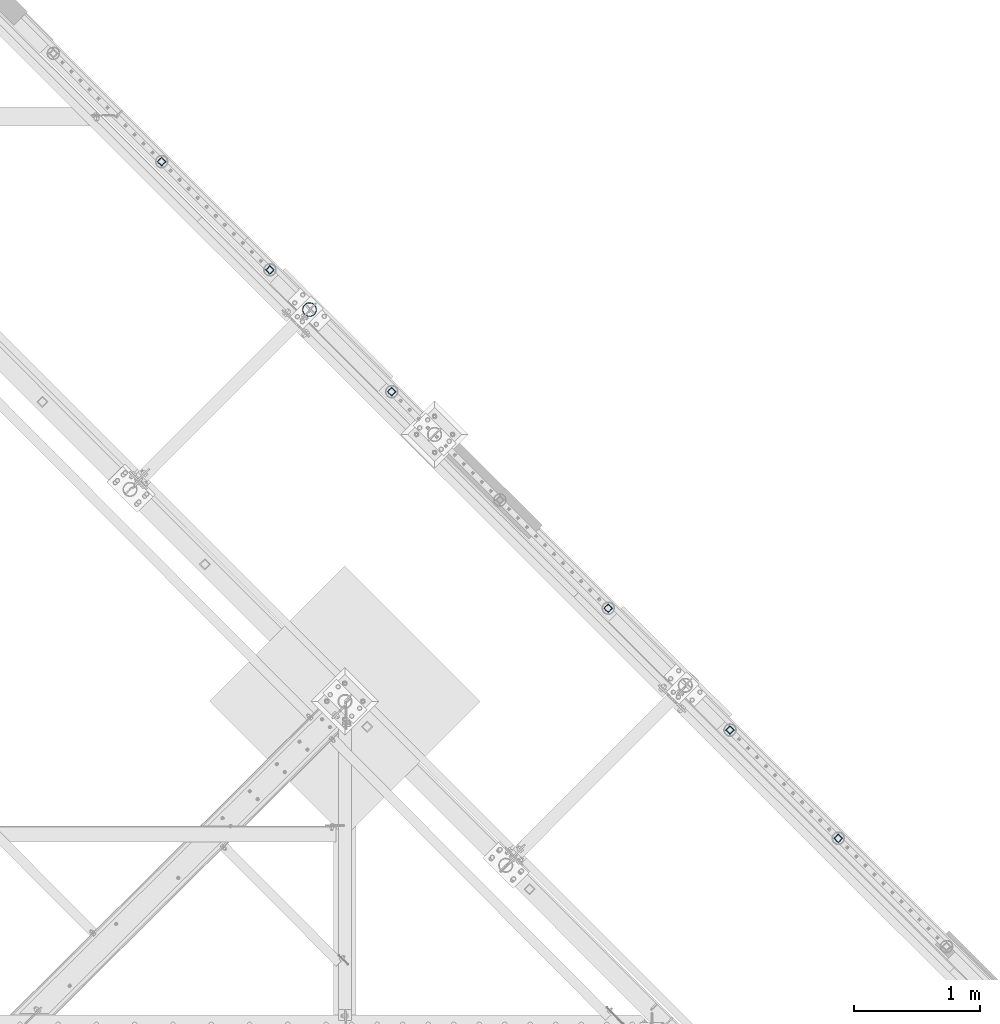
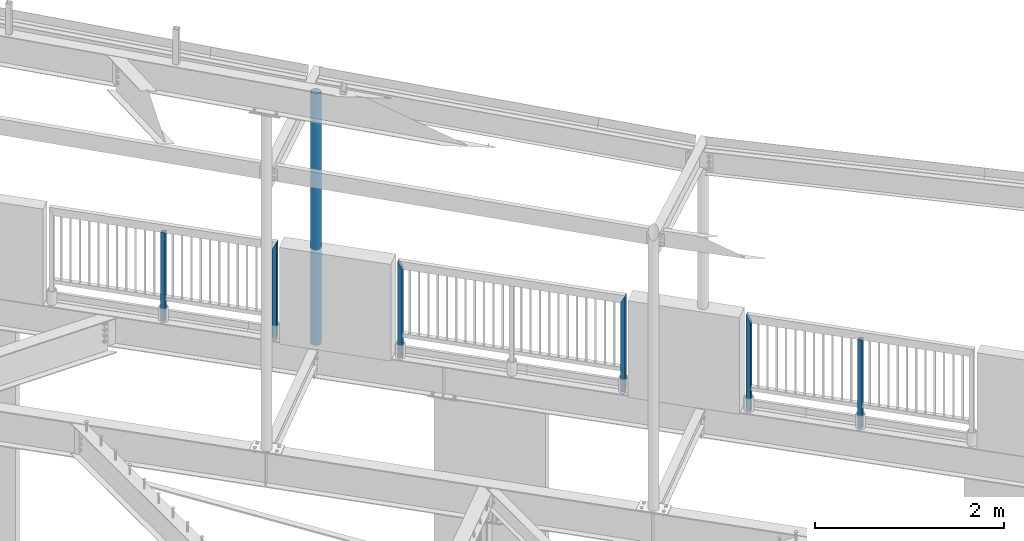
# One storey, part 139 of 975: 7 columns.
"""IFC2X3 building model written with IfcOpenShell, lengths in millimetres."""

from ifc_helpers import new_model, si_unit, frame, origin_with_axes, place, context, subcontext, project, spatial, faceted_brep, material, type_object, element, save


model = new_model("IFC2X3")

# Units and contexts
model_context = context("Model", 3, precision=1e-05, world=origin_with_axes())
body_context = subcontext(model_context, "Body", "Model", "MODEL_VIEW")
ifc_project = project(units=[si_unit("LENGTHUNIT", "METRE", prefix="MILLI"), si_unit("AREAUNIT", "SQUARE_METRE"), si_unit("VOLUMEUNIT", "CUBIC_METRE"), si_unit("MASSUNIT", "GRAM", prefix="KILO"), si_unit("TIMEUNIT", "SECOND"), si_unit("PLANEANGLEUNIT", "RADIAN"), si_unit("SOLIDANGLEUNIT", "STERADIAN"), si_unit("THERMODYNAMICTEMPERATUREUNIT", "DEGREE_CELSIUS"), si_unit("LUMINOUSINTENSITYUNIT", "LUMEN")], contexts=[model_context])

# Site, building, storey
site_placement = place(None, origin_with_axes())
site = spatial("IfcSite", under=ifc_project, at=site_placement, CompositionType="ELEMENT")
building_placement = place(site_placement, origin_with_axes())
building = spatial("IfcBuilding", under=site, at=building_placement, Name="Undefined", CompositionType="ELEMENT")
storey_placement = place(building_placement, origin_with_axes())
storey = spatial("IfcBuildingStorey", under=building, at=storey_placement, Name="Undefined", CompositionType="ELEMENT", Elevation=0.0)

# Columns
ifc_material_1 = material()
column_type_1 = type_object("IfcColumnType", Name="HSS2X2X.188_TUBES", PredefinedType="NOTDEFINED")
column_1_placement = place(storey_placement, frame((28372.9579755447, 20262.0679609286, 3937.00071954323), z_axis=(-0.707106781186601, 0.707106781186494, 2.36468622460961e-14), x_axis=(-5.04999999806568e-07, 5.04999999806568e-07, 0.999999999999745)))
element("IfcColumn", 1, at=column_1_placement, inside=storey, type_object=column_type_1, material=ifc_material_1, Name="HANDRAIL", ObjectType="HSS2X2X.188_TUBES", context=body_context, shape_type="Brep", body=[
    faceted_brep([(0.0, 20.6374999999753, -20.6375000000298), (0.0, -20.6375000000153, -20.6375000000153), (1142.9992657244, -20.6374999999534, -20.6375000019689), (1142.99926572435, 20.6374999999462, -20.6375000019689), (0.0, -20.6374999999825, 20.6375000000335), (1142.99929520217, -20.6374999999607, 20.6374999979416), (0.0, 20.6375000000116, 20.6375000000189), (1142.99929520212, 20.6374999999462, 20.6374999979416), (0.0, 25.3999999999724, -25.4000000000342), (0.0, 25.400000000016, 25.4000000000196), (1142.99929860339, 25.399999999936, 25.3999999979333), (1142.99926232306, 25.399999999936, -25.4000000019587), (0.0, -25.399999999976, 25.4000000000378), (1142.99929860346, -25.3999999999432, 25.3999999979333), (0.0, -25.400000000016, -25.4000000000196), (1142.99926232313, -25.3999999999432, -25.4000000019605)], [[[0, 1, 2, 3]], [[1, 4, 5, 2]], [[4, 6, 7, 5]], [[6, 0, 3, 7]], [[8, 9, 10, 11]], [[9, 12, 13, 10]], [[12, 14, 15, 13]], [[14, 8, 11, 15]], [[13, 15, 11, 10], [5, 7, 3, 2]], [[14, 12, 9, 8], [6, 4, 1, 0]]]),
])
column_2_placement = place(storey_placement, frame((29234.9811722542, 19399.8762678364, 3937.00001179213), z_axis=(-0.707106781186601, 0.707106781186494, 2.36468622460961e-14), x_axis=(0.0, 0.0, 1.0)))
element("IfcColumn", 2, at=column_2_placement, inside=storey, type_object=column_type_1, material=ifc_material_1, Name="HANDRAIL", ObjectType="HSS2X2X.188_TUBES", context=body_context, shape_type="Brep", body=[
    faceted_brep([(0.0, 20.6374999999753, -20.6375000000298), (0.0, -20.6375000000153, -20.6375000000153), (1235.074979717, -20.6374999999462, -20.6374999999462), (1235.07091767483, 20.6374999999871, -20.6375000000007), (0.0, -20.6374999999825, 20.6375000000335), (1152.52905859553, -20.6375000000121, 20.6375000000007), (0.0, 20.6375000000116, 20.6375000000189), (1152.52497980387, 20.6374999999534, 20.6374999999534), (0.0, 25.3999999999724, -25.4000000000342), (0.0, 25.400000000016, 25.4000000000196), (1143.0, 25.4000000000051, 25.4000000000378), (1244.59503672188, 25.399999999936, -25.3999999999396), (0.0, -25.399999999976, 25.4000000000378), (1143.00493968616, -25.399999999936, 25.399999999936), (0.0, -25.400000000016, -25.4000000000196), (1244.59997970698, -25.399999999936, -25.399999999936)], [[[0, 1, 2, 3]], [[1, 4, 5, 2]], [[4, 6, 7, 5]], [[6, 0, 3, 7]], [[8, 9, 10, 11]], [[9, 12, 13, 10]], [[12, 14, 15, 13]], [[14, 8, 11, 15]], [[13, 15, 11, 10], [5, 7, 3, 2]], [[14, 12, 9, 8], [6, 4, 1, 0]]]),
])
column_3_placement = place(storey_placement, frame((30204.763725505, 18429.9433050581, 3937.00002018607), z_axis=(-0.707106781186601, 0.707106781186494, 2.36468622460961e-14), x_axis=(0.0, 0.0, 1.0)))
element("IfcColumn", 3, at=column_3_placement, inside=storey, type_object=column_type_1, material=ifc_material_1, Name="HANDRAIL", ObjectType="HSS2X2X.188_TUBES", context=body_context, shape_type="Brep", body=[
    faceted_brep([(0.0, 20.6374999999753, -20.6375000000298), (0.0, -20.6375000000153, -20.6375000000153), (1152.52497983932, -20.6374999999462, -20.6374999999525), (1152.52900291014, 20.6374999999462, -20.6374999999489), (0.0, -20.6374999999825, 20.6375000000335), (1235.07095675167, -20.6374999999462, 20.6374999999471), (0.0, 20.6375000000116, 20.6375000000189), (1235.07497982248, 20.6374999999534, 20.6374999999471), (0.0, 25.3999999999724, -25.4000000000342), (0.0, 25.400000000016, 25.4000000000196), (1244.59997982054, 25.399999999936, 25.3999999999351), (1143.00493131304, 25.399999999936, -25.3999999999387), (0.0, -25.399999999976, 25.4000000000378), (1244.59502834876, -25.399999999936, 25.3999999999369), (0.0, -25.400000000016, -25.4000000000196), (1143.0, -25.4000000000106, -25.4000000000451)], [[[0, 1, 2, 3]], [[1, 4, 5, 2]], [[4, 6, 7, 5]], [[6, 0, 3, 7]], [[8, 9, 10, 11]], [[9, 12, 13, 10]], [[12, 14, 15, 13]], [[14, 8, 11, 15]], [[13, 15, 11, 10], [5, 7, 3, 2]], [[14, 12, 9, 8], [6, 4, 1, 0]]]),
])
column_4_placement = place(storey_placement, frame((31928.8963940776, 16705.6425683967, 3937.00001179213), z_axis=(-0.707106781186601, 0.707106781186494, 2.36468622460961e-14), x_axis=(0.0, 0.0, 1.0)))
element("IfcColumn", 4, at=column_4_placement, inside=storey, type_object=column_type_1, material=ifc_material_1, Name="HANDRAIL", ObjectType="HSS2X2X.188_TUBES", context=body_context, shape_type="Brep", body=[
    faceted_brep([(0.0, 20.6374999999753, -20.6375000000298), (0.0, -20.6375000000153, -20.6375000000153), (1235.074979717, -20.6374999999462, -20.6374999999462), (1235.07091767483, 20.6374999999871, -20.6375000000007), (0.0, -20.6374999999825, 20.6375000000335), (1152.52905859553, -20.6375000000121, 20.6375000000007), (0.0, 20.6375000000116, 20.6375000000189), (1152.52497980387, 20.6374999999534, 20.6374999999534), (0.0, 25.3999999999724, -25.4000000000342), (0.0, 25.400000000016, 25.4000000000196), (1143.0, 25.4000000000051, 25.4000000000378), (1244.59503672188, 25.399999999936, -25.3999999999396), (0.0, -25.399999999976, 25.4000000000378), (1143.00493968616, -25.399999999936, 25.399999999936), (0.0, -25.400000000016, -25.4000000000196), (1244.59997970698, -25.399999999936, -25.399999999936)], [[[0, 1, 2, 3]], [[1, 4, 5, 2]], [[4, 6, 7, 5]], [[6, 0, 3, 7]], [[8, 9, 10, 11]], [[9, 12, 13, 10]], [[12, 14, 15, 13]], [[14, 8, 11, 15]], [[13, 15, 11, 10], [5, 7, 3, 2]], [[14, 12, 9, 8], [6, 4, 1, 0]]]),
])
column_5_placement = place(storey_placement, frame((32898.6853359089, 15735.7032162826, 3937.00002018607), z_axis=(-0.707106781186601, 0.707106781186494, 2.36468622460961e-14), x_axis=(0.0, 0.0, 1.0)))
element("IfcColumn", 5, at=column_5_placement, inside=storey, type_object=column_type_1, material=ifc_material_1, Name="HANDRAIL", ObjectType="HSS2X2X.188_TUBES", context=body_context, shape_type="Brep", body=[
    faceted_brep([(0.0, 20.6374999999753, -20.6375000000298), (0.0, -20.6375000000153, -20.6375000000153), (1152.52497983932, -20.6374999999462, -20.6374999999525), (1152.52900291014, 20.6374999999462, -20.6374999999489), (0.0, -20.6374999999825, 20.6375000000335), (1235.07095675167, -20.6374999999462, 20.6374999999471), (0.0, 20.6375000000116, 20.6375000000189), (1235.07497982248, 20.6374999999534, 20.6374999999471), (0.0, 25.3999999999724, -25.4000000000342), (0.0, 25.400000000016, 25.4000000000196), (1244.59997982054, 25.399999999936, 25.3999999999351), (1143.00493131304, 25.399999999936, -25.3999999999387), (0.0, -25.399999999976, 25.4000000000378), (1244.59502834876, -25.399999999936, 25.3999999999369), (0.0, -25.400000000016, -25.4000000000196), (1143.0, -25.4000000000106, -25.4000000000451)], [[[0, 1, 2, 3]], [[1, 4, 5, 2]], [[4, 6, 7, 5]], [[6, 0, 3, 7]], [[8, 9, 10, 11]], [[9, 12, 13, 10]], [[12, 14, 15, 13]], [[14, 8, 11, 15]], [[13, 15, 11, 10], [5, 7, 3, 2]], [[14, 12, 9, 8], [6, 4, 1, 0]]]),
])
column_6_placement = place(storey_placement, frame((33760.7948077719, 14873.5941727134, 3937.00071954323), z_axis=(-0.707106781186601, 0.707106781186494, 2.36468622460961e-14), x_axis=(-5.04999999806568e-07, 5.04999999806568e-07, 0.999999999999745)))
element("IfcColumn", 6, at=column_6_placement, inside=storey, type_object=column_type_1, material=ifc_material_1, Name="HANDRAIL", ObjectType="HSS2X2X.188_TUBES", context=body_context, shape_type="Brep", body=[
    faceted_brep([(0.0, 20.6374999999753, -20.6375000000298), (0.0, -20.6375000000153, -20.6375000000153), (1142.9992657244, -20.6374999999534, -20.6375000019689), (1142.99926572435, 20.6374999999462, -20.6375000019689), (0.0, -20.6374999999825, 20.6375000000335), (1142.99929520217, -20.6374999999607, 20.6374999979416), (0.0, 20.6375000000116, 20.6375000000189), (1142.99929520212, 20.6374999999462, 20.6374999979416), (0.0, 25.3999999999724, -25.4000000000342), (0.0, 25.400000000016, 25.4000000000196), (1142.99929860339, 25.399999999936, 25.3999999979333), (1142.99926232306, 25.399999999936, -25.4000000019587), (0.0, -25.399999999976, 25.4000000000378), (1142.99929860346, -25.3999999999432, 25.3999999979333), (0.0, -25.400000000016, -25.4000000000196), (1142.99926232313, -25.3999999999432, -25.4000000019605)], [[[0, 1, 2, 3]], [[1, 4, 5, 2]], [[4, 6, 7, 5]], [[6, 0, 3, 7]], [[8, 9, 10, 11]], [[9, 12, 13, 10]], [[12, 14, 15, 13]], [[14, 8, 11, 15]], [[13, 15, 11, 10], [5, 7, 3, 2]], [[14, 12, 9, 8], [6, 4, 1, 0]]]),
])
ifc_material_2 = material(Name="STEEL/A53")
column_type_2 = type_object("IfcColumnType", Name="PIPE4STD", PredefinedType="NOTDEFINED")
column_7_placement = place(storey_placement, frame((29550.2902594241, 19083.7086945062, 3937.0), z_axis=(0.707106781186548, 0.707106781186548, 0.0), x_axis=(0.0, 0.0, 1.0)))
element("IfcColumn", 7, at=column_7_placement, inside=storey, type_object=column_type_2, material=ifc_material_2, Name="COLUMN", ObjectType="PIPE4STD", context=body_context, shape_type="Brep", body=[
    faceted_brep([(12.7000000000007, -51.1301999999359, 6.54836185276508e-11), (12.7000000000007, -48.6277098894352, 15.8001007258354), (3253.42430798703, -48.6277098893588, 15.8001007257481), (3254.11850560688, -51.1301999998759, 0.0), (12.7000000000007, -41.3652007257788, 30.0535775067838), (3252.79827711976, -41.3652007256915, 30.0535775066892), (12.7000000000007, -30.0535775067819, 41.3652007257842), (3252.30169326818, -30.053577506691, 41.3652007256896), (12.7000000000007, -15.8001007258317, 48.6277098894388), (3251.98316551958, -15.8001007257517, 48.6277098893552), (12.7000000000007, -6.00266503170133e-11, 51.1301999999414), (3251.87387358932, 0.0, 51.1301999998759), (12.7000000000007, 15.8001007257153, 48.6277098894025), (3251.98451573299, 15.8001007257517, 48.6277098893552), (12.7000000000007, 30.0535775066819, 41.3652007257042), (3252.3042615267, 30.0535775066892, 41.3652007256896), (12.7000000000007, 41.3652007257078, 30.0535775066783), (3252.80181202436, 41.3652007256896, 30.0535775066892), (12.7000000000007, 48.6277098894061, 15.8001007257117), (3253.42846351661, 48.6277098893588, 15.8001007257481), (12.7000000000007, 51.1301999999469, -6.54836185276508e-11), (3254.12287498925, 51.1301999998759, 0.0), (12.7000000000007, 48.6277098894425, -15.8001007258354), (3254.81707260911, 48.6277098893588, -15.8001007257481), (12.7000000000007, 41.3652007257861, -30.0535775067838), (3255.44310347637, 41.3652007256915, -30.0535775066892), (12.7000000000007, 30.0535775067892, -41.3652007257842), (3255.93968732795, 30.053577506691, -41.3652007256896), (12.7000000000007, 15.800100725839, -48.6277098894388), (3256.25821507655, 15.8001007257517, -48.6277098893552), (12.7000000000007, 7.09405867382884e-11, -51.1301999999414), (3256.36750700682, 0.0, -51.1301999998759), (12.7000000000007, -15.8001007257044, -48.6277098893988), (3256.25686486314, -15.8001007257517, -48.6277098893552), (12.7000000000007, -30.0535775066746, -41.3652007257042), (3255.93711906943, -30.0535775066892, -41.3652007256896), (12.7000000000007, -41.3652007257006, -30.0535775066746), (3255.43956857178, -41.3652007256896, -30.0535775066892), (12.7000000000007, -48.6277098893952, -15.800100725708), (3254.81291707953, -48.6277098893588, -15.8001007257481), (12.7000000000007, -57.149999999936, 7.27595761418343e-11), (12.7000000000007, -54.3528799061787, -17.6603212284354), (3254.89441620879, -54.3528799061351, -17.6603212284899), (3254.11824839287, -57.1499999998632, 0.0), (12.7000000000007, -46.2353212284306, -33.5919271684179), (3255.59484634171, -46.2353212284179, -33.5919271684324), (12.7000000000007, -33.5919271684143, -46.2353212284324), (3256.15097581003, -33.5919271684361, -46.2353212284143), (12.7000000000007, -17.6603212284317, -54.3528799061824), (3256.5083667866, -17.6603212284863, -54.3528799061387), (12.7000000000007, 7.45785655453801e-11, -57.149999999936), (3256.63203535256, 0.0, -57.1499999998632), (12.7000000000007, 17.6603212285845, -54.3528799062296), (3256.50987596701, 17.6603212284863, -54.3528799061387), (12.7000000000007, 33.5919271685379, -46.2353212285198), (3256.15384644176, 33.5919271684343, -46.2353212284143), (12.7000000000007, 46.2353212285234, -33.5919271685343), (3255.59879742732, 46.2353212284161, -33.5919271684324), (12.7000000000007, 54.3528799062333, -17.6603212285772), (3254.8990609885, 54.3528799061351, -17.6603212284899), (12.7000000000007, 57.1499999999414, -7.27595761418343e-11), (3254.12313220327, 57.1499999998632, 0.0), (12.7000000000007, 54.3528799061896, 17.6603212284354), (3253.34696438734, 54.3528799061351, 17.6603212284899), (12.7000000000007, 46.2353212284361, 33.5919271684179), (3252.64653425443, 46.2353212284179, 33.5919271684324), (12.7000000000007, 33.5919271684197, 46.2353212284361), (3252.09040478611, 33.5919271684361, 46.2353212284143), (12.7000000000007, 17.6603212284426, 54.3528799061824), (3251.73301380953, 17.6603212284863, 54.3528799061387), (12.7000000000007, -6.91215973347425e-11, 57.1499999999396), (3251.60934524358, 0.0, 57.1499999998632), (12.7000000000007, -17.6603212285736, 54.3528799062333), (3251.73150462912, -17.6603212284863, 54.3528799061387), (12.7000000000007, -33.5919271685307, 46.2353212285234), (3252.08753415438, -33.5919271684361, 46.2353212284143), (12.7000000000007, -46.2353212285161, 33.5919271685343), (3252.64258316881, -46.2353212284179, 33.5919271684324), (12.7000000000007, -54.3528799062224, 17.6603212285772), (3253.34231960764, -54.3528799061351, 17.6603212284899)], [[[0, 1, 2, 3]], [[1, 4, 5, 2]], [[4, 6, 7, 5]], [[6, 8, 9, 7]], [[8, 10, 11, 9]], [[10, 12, 13, 11]], [[12, 14, 15, 13]], [[14, 16, 17, 15]], [[16, 18, 19, 17]], [[18, 20, 21, 19]], [[20, 22, 23, 21]], [[22, 24, 25, 23]], [[24, 26, 27, 25]], [[26, 28, 29, 27]], [[28, 30, 31, 29]], [[30, 32, 33, 31]], [[32, 34, 35, 33]], [[34, 36, 37, 35]], [[36, 38, 39, 37]], [[38, 0, 3, 39]], [[40, 41, 42, 43]], [[41, 44, 45, 42]], [[44, 46, 47, 45]], [[46, 48, 49, 47]], [[48, 50, 51, 49]], [[50, 52, 53, 51]], [[52, 54, 55, 53]], [[54, 56, 57, 55]], [[56, 58, 59, 57]], [[58, 60, 61, 59]], [[60, 62, 63, 61]], [[62, 64, 65, 63]], [[64, 66, 67, 65]], [[66, 68, 69, 67]], [[68, 70, 71, 69]], [[70, 72, 73, 71]], [[72, 74, 75, 73]], [[74, 76, 77, 75]], [[76, 78, 79, 77]], [[78, 40, 43, 79]], [[45, 47, 49, 51, 53, 55, 57, 59, 61, 63, 65, 67, 69, 71, 73, 75, 77, 79, 43, 42], [5, 7, 9, 11, 13, 15, 17, 19, 21, 23, 25, 27, 29, 31, 33, 35, 37, 39, 3, 2]], [[78, 76, 74, 72, 70, 68, 66, 64, 62, 60, 58, 56, 54, 52, 50, 48, 46, 44, 41, 40], [38, 36, 34, 32, 30, 28, 26, 24, 22, 20, 18, 16, 14, 12, 10, 8, 6, 4, 1, 0]]]),
])

save(model, "model.ifc")
